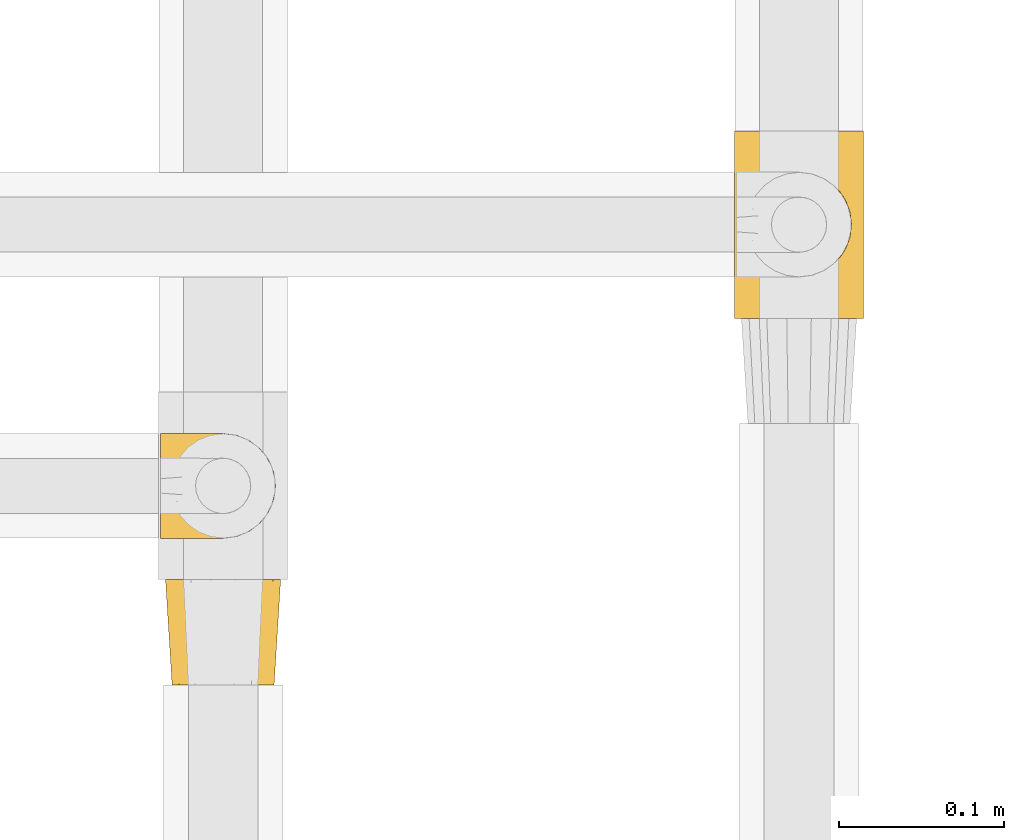
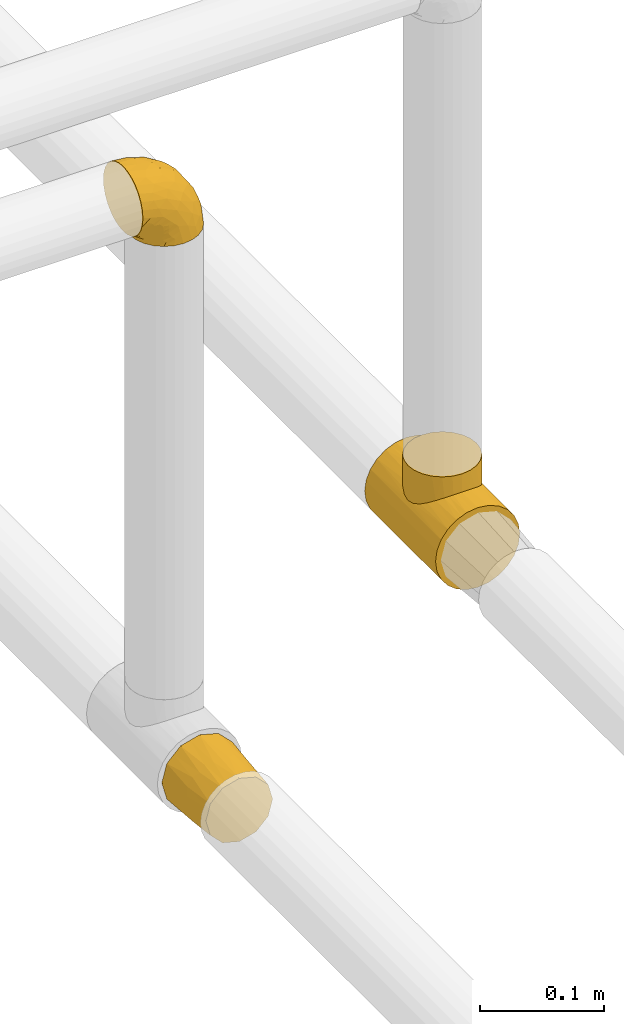
# One storey, part 14 of 39: 3 coverings.
"""IFC2X3 building model written with IfcOpenShell, lengths in millimetres."""

from ifc_helpers import new_model, entity, si_unit, converted_unit, derived_unit, direction, frame, origin, place, context, subcontext, project, spatial, faceted_brep, element, save


model = new_model("IFC2X3")

# Units and contexts
model_context = context("Model", 3, precision=0.01, world=origin(), true_north=direction((6.12303176911189e-17, 1.0)))
body_context = subcontext(model_context, "Body", "Model", "MODEL_VIEW")
ifc_project = project(units=[si_unit("LENGTHUNIT", "METRE", prefix="MILLI"), si_unit("AREAUNIT", "SQUARE_METRE"), si_unit("VOLUMEUNIT", "CUBIC_METRE"), converted_unit("PLANEANGLEUNIT", "DEGREE", entity("IfcRatioMeasure", 0.0174532925199433), si_unit("PLANEANGLEUNIT", "RADIAN"), dimensions=[0, 0, 0, 0, 0, 0, 0]), si_unit("MASSUNIT", "GRAM", prefix="KILO"), derived_unit("MASSDENSITYUNIT", [(si_unit("MASSUNIT", "GRAM", prefix="KILO"), 1), (si_unit("LENGTHUNIT", "METRE"), -3)]), derived_unit("MOMENTOFINERTIAUNIT", [(si_unit("LENGTHUNIT", "METRE"), 4)]), si_unit("TIMEUNIT", "SECOND"), si_unit("FREQUENCYUNIT", "HERTZ"), si_unit("THERMODYNAMICTEMPERATUREUNIT", "DEGREE_CELSIUS"), derived_unit("THERMALTRANSMITTANCEUNIT", [(si_unit("MASSUNIT", "GRAM", prefix="KILO"), 1), (si_unit("THERMODYNAMICTEMPERATUREUNIT", "KELVIN"), -1), (si_unit("TIMEUNIT", "SECOND"), -3)]), derived_unit("VOLUMETRICFLOWRATEUNIT", [(si_unit("LENGTHUNIT", "METRE"), 3), (si_unit("TIMEUNIT", "SECOND"), -1)]), derived_unit("MASSFLOWRATEUNIT", [(si_unit("MASSUNIT", "GRAM", prefix="KILO"), 1), (si_unit("TIMEUNIT", "SECOND"), -1)]), derived_unit("ROTATIONALFREQUENCYUNIT", [(si_unit("TIMEUNIT", "SECOND"), -1)]), si_unit("ELECTRICCURRENTUNIT", "AMPERE"), si_unit("ELECTRICVOLTAGEUNIT", "VOLT"), si_unit("POWERUNIT", "WATT"), si_unit("FORCEUNIT", "NEWTON", prefix="KILO"), si_unit("ILLUMINANCEUNIT", "LUX"), si_unit("LUMINOUSFLUXUNIT", "LUMEN"), si_unit("LUMINOUSINTENSITYUNIT", "CANDELA"), derived_unit("USERDEFINED", [(si_unit("MASSUNIT", "GRAM", prefix="KILO"), -1), (si_unit("LENGTHUNIT", "METRE"), -2), (si_unit("TIMEUNIT", "SECOND"), 3), (si_unit("LUMINOUSFLUXUNIT", "LUMEN"), 1)]), derived_unit("LINEARVELOCITYUNIT", [(si_unit("LENGTHUNIT", "METRE"), 1), (si_unit("TIMEUNIT", "SECOND"), -1)]), si_unit("PRESSUREUNIT", "PASCAL"), derived_unit("USERDEFINED", [(si_unit("LENGTHUNIT", "METRE"), -2), (si_unit("MASSUNIT", "GRAM", prefix="KILO"), 1), (si_unit("TIMEUNIT", "SECOND"), -2)]), derived_unit("LINEARFORCEUNIT", [(si_unit("MASSUNIT", "GRAM", prefix="KILO"), 1), (si_unit("LENGTHUNIT", "METRE"), 1), (si_unit("TIMEUNIT", "SECOND"), -2), (si_unit("LENGTHUNIT", "METRE"), -1)]), derived_unit("PLANARFORCEUNIT", [(si_unit("MASSUNIT", "GRAM", prefix="KILO"), 1), (si_unit("LENGTHUNIT", "METRE"), 1), (si_unit("TIMEUNIT", "SECOND"), -2), (si_unit("LENGTHUNIT", "METRE"), -2)])], contexts=[model_context])

# Site, building, storey
site_placement = place(None, origin())
site = spatial("IfcSite", under=ifc_project, at=site_placement, CompositionType="ELEMENT")
building_placement = place(site_placement, origin())
building = spatial("IfcBuilding", under=site, at=building_placement, CompositionType="ELEMENT")
storey_placement = place(building_placement, frame((0.0, 0.0, 24000.0)))
storey = spatial("IfcBuildingStorey", under=building, at=storey_placement, Name="07", CompositionType="ELEMENT", Elevation=24000.0)

# Coverings
covering_1_placement = place(storey_placement, frame((31040.4, 8217.73, 3160.4)))
element("IfcCovering", 1, at=covering_1_placement, inside=storey, Name=":ADSK_", ObjectType=":ADSK_", PredefinedType="INSULATION", context=body_context, shape_type="Brep", body=[
    faceted_brep([(1.6, 26.36, 70.65), (1.6, 33.45, 71.45), (1.6, 40.54, 70.65), (1.6, 47.27, 68.29), (1.6, 53.31, 64.49), (1.6, 58.35, 59.45), (1.6, 62.14, 53.41), (1.6, 64.5, 46.68), (1.6, 65.3, 39.6), (1.6, 64.86, 35.69), (1.6, 64.5, 32.5), (1.6, 63.32, 29.14), (1.6, 62.14, 25.77), (1.6, 58.34, 19.73), (1.6, 53.3, 14.69), (1.6, 47.26, 10.9), (1.6, 40.53, 8.54), (1.6, 33.45, 7.75), (1.6, 26.35, 8.54), (1.6, 19.62, 10.9), (1.6, 13.58, 14.7), (1.6, 8.54, 19.74), (1.6, 4.75, 25.78), (1.6, 3.57, 29.15), (1.6, 2.39, 32.51), (1.6, 2.03, 35.69), (1.6, 1.81, 37.64), (1.6, 1.6, 39.6), (1.6, 2.39, 46.69), (1.6, 4.75, 53.42), (1.6, 8.55, 59.46), (1.6, 13.59, 64.5), (1.6, 19.63, 68.29), (23.67, 61.03, 1.6), (27.51, 62.62, 1.6), (31.35, 64.21, 1.6), (35.67, 64.78, 1.6), (37.63, 65.04, 1.6), (39.6, 65.3, 1.6), (47.84, 64.21, 1.6), (55.52, 61.03, 1.6), (62.12, 55.97, 1.6), (67.18, 49.37, 1.6), (70.36, 41.69, 1.6), (71.45, 33.45, 1.6), (70.36, 25.2, 1.6), (67.18, 17.52, 1.6), (62.12, 10.92, 1.6), (55.52, 5.86, 1.6), (47.84, 2.68, 1.6), (39.6, 1.6, 1.6), (35.67, 2.11, 1.6), (31.35, 2.68, 1.6), (27.51, 4.27, 1.6), (23.67, 5.86, 1.6), (20.37, 8.39, 1.6), (17.07, 10.92, 1.6), (12.01, 17.52, 1.6), (8.83, 25.2, 1.6), (7.75, 33.45, 1.6), (8.83, 41.69, 1.6), (12.01, 49.37, 1.6), (17.07, 55.97, 1.6), (20.37, 58.5, 1.6), (33.94, 2.87, 35.56), (20.6, 1.6, 34.5), (24.07, 1.6, 31.03), (27.55, 1.6, 27.55), (31.03, 1.6, 24.07), (34.5, 1.6, 20.6), (68.79, 33.45, 14.96), (53.62, 10.76, 32.2), (50.17, 5.89, 25.13), (58.62, 9.64, 17.37), (67.51, 22.45, 17.86), (61.03, 16.56, 27.91), (64.5, 15.17, 13.85), (17.98, 12.49, 61.37), (61.71, 25.02, 34.87), (52.25, 18.64, 44.22), (16.72, 2.29, 43.56), (39.09, 6.11, 40.93), (25.86, 5.18, 48.36), (44.07, 2.43, 17.22), (44.36, 11.11, 44.67), (31.35, 26.19, 63.86), (17.72, 24.02, 68.09), (29.45, 19.02, 61.87), (52.37, 4.77, 12.15), (35.28, 1.6, 17.69), (36.06, 1.6, 14.79), (36.84, 1.6, 11.89), (37.61, 1.6, 8.99), (38.11, 1.6, 7.14), (38.61, 1.6, 5.29), (14.07, 7.57, 56.77), (13.65, 17.54, 66.08), (14.96, 33.45, 68.79), (13.32, 4.36, 51.2), (3.44, 1.6, 39.1), (5.29, 1.6, 38.61), (8.99, 1.6, 37.61), (11.89, 1.6, 36.84), (14.79, 1.6, 36.06), (17.69, 1.6, 35.28), (29.19, 9.86, 54.2), (28.91, 14.05, 58.65), (68.17, 28.37, 21.36), (28.33, 33.45, 66.13), (53.45, 25.8, 46.99), (58.56, 33.45, 39.66), (50.99, 33.45, 50.99), (43.14, 22.54, 55.34), (39.23, 15.6, 53.83), (66.13, 33.45, 28.33), (45.6, 28.45, 55.34), (39.66, 33.45, 58.56), (18.04, 9.47, 6.06), (22.76, 5.83, 8.03), (21.95, 5.65, 11.06), (32.18, 2.31, 8.19), (29.08, 2.89, 10.89), (20.77, 2.68, 24.37), (4.75, 22.04, 9.23), (11.03, 5.47, 22.33), (6.78, 5.05, 24.59), (5.68, 7.86, 20.19), (7.71, 25.25, 5.45), (4.42, 28.09, 7.56), (5.94, 33.45, 5.94), (14.52, 12.77, 6.36), (11.63, 2.62, 29.84), (6.6, 3.56, 28.12), (7.33, 11.92, 14.94), (12.48, 11.98, 11.12), (7.99, 17.45, 9.87), (11.14, 17.1, 6.36), (14.07, 7.66, 16.34), (15.37, 4.47, 22.18), (10.81, 7.62, 18.62), (7.89, 2.29, 32.34), (26.18, 3.16, 15.29), (5.8, 16.64, 11.7), (9.94, 12.23, 13.14), (22.23, 4.54, 15.04), (18.39, 7.84, 10.61), (17.71, 2.55, 27.21), (16.87, 7.37, 14.05), (13.24, 3.18, 27.14), (24.95, 4.97, 5.74), (26.59, 2.38, 19.92), (26.16, 1.99, 23.61), (22.11, 3.56, 19.14), (17.43, 4.66, 20.12), (4.75, 44.85, 9.23), (5.8, 50.24, 11.69), (7.99, 49.43, 9.87), (14.07, 59.23, 16.33), (10.06, 54.76, 13.17), (11.54, 59.54, 18.65), (7.71, 41.64, 5.45), (7.89, 64.6, 32.33), (8.99, 65.3, 37.61), (11.89, 65.3, 36.84), (14.79, 65.3, 36.06), (4.42, 38.79, 7.56), (22.42, 62.38, 14.85), (27.95, 64.44, 17.26), (22.22, 61.27, 10.58), (39.1, 65.3, 3.44), (36.84, 65.3, 11.89), (37.61, 65.3, 8.99), (38.61, 65.3, 5.29), (21.49, 59.93, 5.65), (26.52, 62.73, 6.88), (18.09, 60.51, 14.93), (18.39, 59.05, 10.6), (13.88, 56.02, 11.09), (11.14, 49.79, 6.36), (32.18, 64.58, 8.19), (34.5, 65.3, 20.6), (31.03, 65.3, 24.07), (11.65, 64.27, 29.86), (5.67, 59.01, 20.16), (6.81, 61.84, 24.58), (5.29, 65.3, 38.61), (7.14, 65.3, 38.11), (7.34, 54.97, 14.93), (36.06, 65.3, 14.79), (31.38, 64.66, 12.32), (19.83, 63.94, 23.91), (27.55, 65.3, 27.55), (22.94, 63.6, 19.33), (6.6, 63.33, 28.11), (17.93, 57.32, 6.0), (14.52, 54.15, 6.44), (17.45, 64.5, 28.13), (11.03, 61.42, 22.32), (17.69, 65.3, 35.28), (20.6, 65.3, 34.5), (12.33, 63.43, 26.65), (30.27, 64.69, 15.34), (35.28, 65.3, 17.69), (25.9, 62.87, 10.31), (24.07, 65.3, 31.03), (58.62, 57.25, 17.37), (13.32, 62.54, 51.19), (16.72, 64.6, 43.56), (44.07, 64.46, 17.22), (61.71, 41.87, 34.87), (67.51, 44.44, 17.86), (61.03, 50.33, 27.92), (50.18, 61.0, 25.12), (33.92, 64.03, 35.57), (39.08, 60.79, 40.93), (53.62, 56.13, 32.19), (68.17, 38.52, 21.36), (52.37, 62.12, 12.15), (64.5, 51.72, 13.85), (25.86, 61.71, 48.35), (14.07, 59.33, 56.76), (29.18, 57.04, 54.19), (29.46, 47.88, 61.86), (17.73, 42.88, 68.09), (31.37, 40.71, 63.85), (17.99, 54.41, 61.36), (53.45, 41.09, 47.0), (39.25, 51.29, 53.81), (28.92, 52.85, 58.64), (13.65, 49.36, 66.07), (52.23, 48.25, 44.24), (43.13, 44.35, 55.34), (44.36, 55.79, 44.67), (45.6, 38.44, 55.34)], [[[0, 1, 2, 3, 4, 5, 6, 7, 8, 9, 10, 11, 12, 13, 14, 15, 16, 17, 18, 19, 20, 21, 22, 23, 24, 25, 26, 27, 28, 29, 30, 31, 32]], [[33, 34, 35, 36, 37, 38, 39, 40, 41, 42, 43, 44, 45, 46, 47, 48, 49, 50, 51, 52, 53, 54, 55, 56, 57, 58, 59, 60, 61, 62, 63]], [[64, 65, 66, 67, 68, 69]], [[45, 44, 70]], [[71, 72, 73]], [[74, 75, 76]], [[77, 31, 30]], [[75, 78, 79]], [[27, 80, 28]], [[74, 46, 45]], [[64, 81, 82]], [[46, 76, 47]], [[83, 50, 49]], [[48, 47, 73]], [[71, 79, 84]], [[85, 86, 87]], [[49, 48, 88]], [[83, 69, 89, 90, 91, 92, 93, 94, 50]], [[95, 77, 30]], [[75, 74, 78]], [[87, 86, 96]], [[96, 86, 32]], [[96, 32, 31]], [[0, 86, 97]], [[83, 64, 69]], [[98, 80, 82]], [[73, 72, 88]], [[64, 80, 65]], [[1, 0, 97]], [[80, 27, 99, 100, 101, 102, 103, 104, 65]], [[77, 105, 106]], [[64, 82, 80]], [[70, 107, 45]], [[77, 95, 105]], [[82, 95, 98]], [[95, 30, 29]], [[74, 107, 78]], [[86, 0, 32]], [[72, 71, 81]], [[85, 108, 86]], [[76, 73, 47]], [[71, 84, 81]], [[109, 110, 111]], [[87, 112, 85]], [[79, 109, 112]], [[79, 112, 113]], [[88, 83, 49]], [[64, 83, 72]], [[31, 77, 96]], [[87, 96, 77]], [[98, 95, 29]], [[105, 95, 82]], [[81, 105, 82]], [[105, 84, 113]], [[29, 28, 98]], [[114, 107, 70]], [[80, 98, 28]], [[73, 75, 71]], [[79, 71, 75]], [[74, 76, 46]], [[73, 76, 75]], [[78, 107, 114]], [[45, 107, 74]], [[87, 113, 112]], [[115, 85, 112]], [[109, 79, 78]], [[113, 87, 106]], [[116, 115, 111]], [[116, 108, 85]], [[79, 113, 84]], [[109, 78, 110]], [[115, 109, 111]], [[85, 115, 116]], [[109, 115, 112]], [[72, 81, 64]], [[105, 81, 84]], [[73, 88, 48]], [[83, 88, 72]], [[86, 108, 97]], [[78, 114, 110]], [[113, 106, 105]], [[87, 77, 106]], [[117, 118, 119]], [[52, 120, 54, 53]], [[91, 120, 52]], [[91, 90, 120]], [[90, 121, 120]], [[122, 67, 66]], [[18, 123, 19]], [[124, 125, 126]], [[127, 59, 58]], [[128, 129, 127]], [[130, 57, 117]], [[131, 132, 125]], [[19, 133, 20]], [[128, 18, 17]], [[134, 135, 136]], [[137, 138, 139]], [[131, 103, 140]], [[22, 140, 23]], [[131, 65, 104, 103]], [[99, 27, 26, 25, 24, 101, 100]], [[141, 118, 121]], [[19, 123, 142]], [[52, 51, 50, 94, 93, 92, 91]], [[129, 128, 17]], [[117, 56, 118]], [[135, 134, 143]], [[139, 126, 133]], [[119, 144, 145]], [[127, 135, 123]], [[136, 58, 57]], [[101, 24, 23]], [[124, 138, 146]], [[140, 101, 23]], [[145, 147, 134]], [[140, 132, 131]], [[140, 103, 102, 101]], [[140, 22, 132]], [[146, 148, 124]], [[121, 69, 141]], [[55, 149, 118]], [[150, 151, 152]], [[147, 137, 134]], [[144, 150, 152]], [[152, 151, 122]], [[138, 122, 146]], [[59, 127, 129]], [[123, 18, 128]], [[58, 136, 127]], [[135, 127, 136]], [[121, 90, 89, 69]], [[120, 121, 149]], [[122, 66, 146]], [[153, 122, 138]], [[141, 69, 68]], [[127, 123, 128]], [[123, 135, 142]], [[143, 142, 135]], [[19, 142, 133]], [[66, 65, 146]], [[148, 65, 131]], [[22, 21, 132]], [[125, 132, 21]], [[126, 125, 21]], [[148, 125, 124]], [[21, 20, 126]], [[133, 126, 20]], [[139, 138, 124]], [[153, 138, 137]], [[126, 139, 124]], [[139, 133, 143]], [[147, 153, 137]], [[152, 122, 153]], [[134, 136, 130]], [[137, 139, 143]], [[144, 147, 145]], [[153, 147, 152]], [[65, 148, 146]], [[125, 148, 131]], [[141, 144, 119]], [[55, 54, 149]], [[137, 143, 134]], [[142, 143, 133]], [[130, 117, 145]], [[57, 56, 117]], [[134, 130, 145]], [[57, 130, 136]], [[150, 144, 141]], [[147, 144, 152]], [[141, 68, 150]], [[151, 68, 67]], [[117, 119, 145]], [[141, 119, 118]], [[68, 151, 150]], [[122, 151, 67]], [[118, 56, 55]], [[120, 149, 54]], [[118, 149, 121]], [[154, 155, 156]], [[157, 158, 159]], [[129, 160, 59]], [[161, 162, 163, 164]], [[165, 160, 129]], [[166, 167, 168]], [[169, 38, 37, 36, 35, 170, 171, 172]], [[63, 173, 174]], [[175, 176, 177]], [[60, 178, 61]], [[179, 35, 34, 33]], [[160, 60, 59]], [[180, 167, 181]], [[129, 17, 165]], [[182, 161, 164]], [[183, 13, 184]], [[9, 8, 185, 186, 162, 10]], [[187, 155, 15]], [[188, 179, 189]], [[187, 15, 14]], [[190, 191, 192]], [[182, 193, 161]], [[194, 176, 168]], [[176, 195, 177]], [[196, 190, 197]], [[11, 10, 162]], [[11, 161, 12]], [[187, 14, 183]], [[12, 161, 193]], [[156, 158, 177]], [[165, 17, 16]], [[194, 195, 176]], [[187, 159, 158]], [[179, 174, 189]], [[182, 164, 198, 199]], [[200, 199, 196]], [[193, 184, 13]], [[194, 168, 173]], [[201, 202, 189]], [[16, 154, 165]], [[160, 156, 178]], [[160, 165, 154]], [[178, 60, 160]], [[170, 35, 179]], [[188, 170, 179]], [[189, 174, 203]], [[174, 179, 33]], [[201, 189, 203]], [[181, 192, 191]], [[167, 180, 201]], [[192, 175, 190]], [[159, 190, 157]], [[15, 154, 16]], [[204, 196, 199]], [[204, 191, 190]], [[160, 154, 156]], [[15, 155, 154]], [[158, 155, 187]], [[203, 173, 168]], [[192, 181, 167]], [[190, 196, 204]], [[200, 196, 197]], [[184, 193, 182]], [[13, 12, 193]], [[200, 184, 182]], [[184, 200, 183]], [[187, 183, 197]], [[14, 13, 183]], [[162, 161, 11]], [[63, 62, 173]], [[174, 33, 63]], [[173, 62, 194]], [[174, 173, 203]], [[62, 61, 194]], [[195, 61, 178]], [[61, 195, 194]], [[177, 195, 178]], [[156, 177, 178]], [[175, 192, 166]], [[166, 168, 176]], [[167, 203, 168]], [[175, 166, 176]], [[167, 166, 192]], [[177, 157, 175]], [[190, 175, 157]], [[187, 197, 159]], [[190, 159, 197]], [[177, 158, 157]], [[155, 158, 156]], [[167, 201, 203]], [[200, 197, 183]], [[202, 201, 180]], [[202, 188, 189]], [[199, 200, 182]], [[41, 40, 205]], [[206, 207, 7]], [[208, 38, 169, 172, 171, 170, 188, 202, 180]], [[209, 210, 211]], [[212, 213, 214]], [[212, 215, 205]], [[43, 210, 216]], [[217, 40, 39]], [[216, 114, 70]], [[208, 213, 212]], [[205, 40, 217]], [[218, 42, 41]], [[216, 209, 114]], [[42, 218, 210]], [[214, 213, 219]], [[219, 220, 221]], [[199, 207, 213]], [[213, 207, 219]], [[8, 7, 207]], [[222, 223, 224]], [[4, 225, 5]], [[2, 97, 223]], [[110, 226, 111]], [[225, 220, 5]], [[227, 221, 228]], [[223, 229, 3]], [[2, 223, 3]], [[230, 231, 226]], [[224, 223, 108]], [[42, 210, 43]], [[230, 209, 211]], [[222, 225, 229]], [[38, 208, 39]], [[3, 229, 4]], [[213, 180, 181, 191, 204, 199]], [[220, 206, 6]], [[5, 220, 6]], [[207, 199, 198, 164, 163, 162, 186, 185, 8]], [[212, 214, 215]], [[218, 205, 211]], [[211, 215, 230]], [[226, 110, 209]], [[222, 231, 227]], [[222, 224, 231]], [[213, 208, 180]], [[217, 208, 212]], [[222, 229, 223]], [[225, 4, 229]], [[221, 220, 225]], [[206, 220, 219]], [[228, 221, 225]], [[214, 221, 232]], [[207, 206, 219]], [[44, 43, 70]], [[7, 6, 206]], [[230, 215, 232]], [[211, 205, 215]], [[205, 218, 41]], [[210, 218, 211]], [[43, 216, 70]], [[209, 216, 210]], [[233, 116, 111]], [[230, 232, 227]], [[224, 116, 233]], [[230, 226, 209]], [[224, 108, 116]], [[230, 227, 231]], [[221, 227, 232]], [[233, 226, 231]], [[225, 222, 228]], [[226, 233, 111]], [[224, 233, 231]], [[221, 214, 219]], [[214, 232, 215]], [[208, 217, 39]], [[205, 217, 212]], [[97, 2, 1]], [[97, 108, 223]], [[110, 114, 209]], [[227, 228, 222]]]),
])
covering_2_placement = place(storey_placement, frame((31043.4, 8130.17, 2623.4)))
element("IfcCovering", 2, at=covering_2_placement, inside=storey, Name=":ADSK_", ObjectType=":ADSK_", PredefinedType="INSULATION", context=body_context, shape_type="Brep", body=[
    faceted_brep([(8.36, 0.0, 46.92), (5.59, 0.0, 36.6), (8.36, 0.0, 26.27), (9.75, 0.0, 21.1), (15.42, 0.0, 15.42), (21.09, 0.0, 9.75), (26.27, 0.0, 8.36), (36.59, 0.0, 5.6), (46.92, 0.0, 8.36), (52.09, 0.0, 9.75), (57.77, 0.0, 15.42), (63.44, 0.0, 21.1), (64.83, 0.0, 26.27), (67.59, 0.0, 36.6), (64.83, 0.0, 46.92), (63.44, 0.0, 52.1), (57.77, 0.0, 57.77), (52.09, 0.0, 63.44), (46.92, 0.0, 64.83), (36.59, 0.0, 67.6), (26.27, 0.0, 64.83), (21.09, 0.0, 63.44), (15.42, 0.0, 57.77), (9.75, 0.0, 52.1), (45.35, 64.0, 69.25), (54.1, 64.0, 66.91), (60.5, 64.0, 60.5), (66.91, 64.0, 54.1), (69.25, 64.0, 45.35), (71.6, 64.0, 36.6), (69.25, 64.0, 27.85), (66.91, 64.0, 19.1), (60.5, 64.0, 12.69), (54.1, 64.0, 6.28), (45.35, 64.0, 3.94), (36.6, 64.0, 1.6), (27.85, 64.0, 3.94), (19.1, 64.0, 6.28), (12.69, 64.0, 12.69), (6.28, 64.0, 19.1), (3.94, 64.0, 27.85), (1.6, 64.0, 36.6), (3.94, 64.0, 45.35), (6.28, 64.0, 54.1), (12.69, 64.0, 60.5), (19.1, 64.0, 66.91), (27.85, 64.0, 69.25), (36.6, 64.0, 71.6), (6.68, 32.0, 22.65), (10.56, 28.99, 16.62), (4.58, 28.84, 29.44), (15.12, 32.0, 11.54), (22.65, 32.0, 6.68), (29.44, 28.84, 4.58), (36.59, 32.0, 3.6), (3.59, 32.0, 36.6), (50.54, 32.0, 6.68), (56.57, 28.99, 10.56), (43.75, 28.84, 4.58), (61.65, 32.0, 15.12), (66.51, 32.0, 22.65), (68.61, 28.84, 29.44), (69.59, 32.0, 36.6), (66.51, 32.0, 50.54), (62.63, 28.99, 56.57), (68.61, 28.84, 43.75), (58.07, 32.0, 61.65), (50.54, 32.0, 66.51), (43.75, 28.84, 68.61), (36.59, 32.0, 69.6), (22.65, 32.0, 66.51), (16.62, 28.99, 62.63), (29.44, 28.84, 68.61), (11.54, 32.0, 58.07), (6.68, 32.0, 50.54), (4.58, 28.84, 43.75)], [[[0, 1, 2, 3, 4, 5, 6, 7, 8, 9, 10, 11, 12, 13, 14, 15, 16, 17, 18, 19, 20, 21, 22, 23]], [[24, 25, 26, 27, 28, 29, 30, 31, 32, 33, 34, 35, 36, 37, 38, 39, 40, 41, 42, 43, 44, 45, 46, 47]], [[48, 40, 39]], [[39, 49, 48]], [[41, 40, 50]], [[40, 48, 50]], [[38, 49, 39]], [[51, 49, 38]], [[6, 52, 53]], [[5, 4, 51]], [[48, 2, 50]], [[53, 35, 54, 7]], [[4, 49, 51]], [[49, 3, 48]], [[49, 4, 3]], [[48, 3, 2]], [[2, 1, 50]], [[50, 1, 55, 41]], [[38, 37, 51]], [[51, 37, 52]], [[5, 52, 6]], [[52, 5, 51]], [[37, 36, 52]], [[53, 52, 36]], [[7, 6, 53]], [[35, 53, 36]], [[56, 34, 33]], [[33, 57, 56]], [[35, 34, 58]], [[34, 56, 58]], [[32, 57, 33]], [[59, 57, 32]], [[12, 60, 61]], [[11, 10, 59]], [[56, 8, 58]], [[61, 29, 62, 13]], [[10, 57, 59]], [[57, 9, 56]], [[57, 10, 9]], [[56, 9, 8]], [[8, 7, 58]], [[58, 7, 54, 35]], [[32, 31, 59]], [[59, 31, 60]], [[11, 60, 12]], [[60, 11, 59]], [[31, 30, 60]], [[61, 60, 30]], [[13, 12, 61]], [[29, 61, 30]], [[63, 28, 27]], [[27, 64, 63]], [[29, 28, 65]], [[28, 63, 65]], [[26, 64, 27]], [[66, 64, 26]], [[18, 67, 68]], [[17, 16, 66]], [[63, 14, 65]], [[68, 47, 69, 19]], [[16, 64, 66]], [[64, 15, 63]], [[64, 16, 15]], [[63, 15, 14]], [[14, 13, 65]], [[65, 13, 62, 29]], [[26, 25, 66]], [[66, 25, 67]], [[17, 67, 18]], [[67, 17, 66]], [[25, 24, 67]], [[68, 67, 24]], [[19, 18, 68]], [[47, 68, 24]], [[70, 46, 45]], [[45, 71, 70]], [[47, 46, 72]], [[46, 70, 72]], [[44, 71, 45]], [[73, 71, 44]], [[0, 74, 75]], [[23, 22, 73]], [[70, 20, 72]], [[75, 41, 55, 1]], [[22, 71, 73]], [[71, 21, 70]], [[71, 22, 21]], [[70, 21, 20]], [[20, 19, 72]], [[72, 19, 69, 47]], [[44, 43, 73]], [[73, 43, 74]], [[23, 74, 0]], [[74, 23, 73]], [[43, 42, 74]], [[75, 74, 42]], [[1, 0, 75]], [[41, 75, 42]]]),
])
covering_3_placement = place(storey_placement, frame((31389.25, 8352.96, 2619.25)))
element("IfcCovering", 3, at=covering_3_placement, inside=storey, Name=":ADSK_", ObjectType=":ADSK_", PredefinedType="INSULATION", context=body_context, shape_type="Brep", body=[
    faceted_brep([(60.32, 114.0, 6.84), (50.88, 114.0, 2.93), (40.75, 114.0, 1.6), (30.61, 114.0, 2.93), (21.17, 114.0, 6.84), (13.06, 114.0, 13.06), (6.84, 114.0, 21.17), (2.93, 114.0, 30.61), (1.6, 114.0, 40.75), (2.93, 114.0, 50.88), (6.84, 114.0, 60.32), (13.06, 114.0, 68.43), (17.12, 114.0, 71.54), (21.17, 114.0, 74.65), (25.89, 114.0, 76.61), (30.61, 114.0, 78.56), (35.68, 114.0, 79.23), (40.75, 114.0, 79.9), (45.81, 114.0, 79.23), (50.88, 114.0, 78.56), (55.6, 114.0, 76.61), (60.32, 114.0, 74.65), (64.37, 114.0, 71.54), (68.43, 114.0, 68.43), (74.65, 114.0, 60.32), (78.56, 114.0, 50.88), (79.9, 114.0, 40.75), (78.56, 114.0, 30.61), (74.65, 114.0, 21.17), (68.43, 114.0, 13.06), (2.93, 0.0, 50.88), (1.6, 0.0, 40.75), (2.93, 0.0, 30.61), (6.84, 0.0, 21.17), (13.06, 0.0, 13.06), (21.17, 0.0, 6.84), (30.61, 0.0, 2.93), (40.75, 0.0, 1.6), (50.88, 0.0, 2.93), (60.32, 0.0, 6.84), (68.43, 0.0, 13.06), (74.65, 0.0, 21.17), (78.56, 0.0, 30.61), (79.9, 0.0, 40.75), (78.56, 0.0, 50.88), (74.65, 0.0, 60.32), (68.43, 0.0, 68.43), (64.37, 0.0, 71.54), (60.32, 0.0, 74.65), (55.6, 0.0, 76.61), (50.88, 0.0, 78.56), (45.81, 0.0, 79.23), (40.75, 0.0, 79.9), (35.68, 0.0, 79.23), (30.61, 0.0, 78.56), (25.89, 0.0, 76.61), (21.17, 0.0, 74.65), (17.12, 0.0, 71.54), (13.06, 0.0, 68.43), (6.84, 0.0, 60.32), (15.77, 37.23, 70.9), (12.16, 42.96, 67.49), (20.53, 32.39, 74.27), (29.82, 86.7, 78.17), (26.39, 85.43, 77.17), (9.77, 49.58, 64.69), (8.9, 57.0, 63.51), (9.77, 64.42, 64.69), (37.0, 88.4, 79.53), (40.75, 88.85, 79.9), (40.75, 25.15, 79.9), (37.0, 25.6, 79.53), (12.16, 71.04, 67.49), (15.77, 76.77, 70.9), (20.53, 81.61, 74.27), (26.39, 28.57, 77.17), (33.25, 26.04, 79.17), (29.82, 27.3, 78.17), (33.25, 87.96, 79.17), (44.49, 25.6, 79.53), (48.24, 26.04, 79.17), (55.1, 28.57, 77.17), (60.96, 32.39, 74.27), (51.67, 27.3, 78.17), (48.24, 87.96, 79.17), (44.49, 88.4, 79.53), (55.1, 85.43, 77.17), (60.96, 81.61, 74.27), (51.67, 86.7, 78.17), (65.72, 76.77, 70.9), (65.72, 37.23, 70.9), (69.33, 42.96, 67.49), (71.72, 49.58, 64.69), (72.6, 57.0, 63.51), (69.33, 71.04, 67.49), (71.72, 64.42, 64.69), (8.9, 57.0, 97.75), (9.98, 48.76, 97.75), (13.16, 41.07, 97.75), (18.22, 34.48, 97.75), (24.82, 29.42, 97.75), (32.5, 26.24, 97.75), (40.75, 25.15, 97.75), (48.99, 26.24, 97.75), (56.67, 29.42, 97.75), (63.27, 34.48, 97.75), (68.33, 41.07, 97.75), (71.51, 48.76, 97.75), (72.6, 57.0, 97.75), (71.51, 65.24, 97.75), (68.33, 72.92, 97.75), (63.27, 79.52, 97.75), (56.67, 84.58, 97.75), (48.99, 87.76, 97.75), (40.75, 88.85, 97.75), (32.5, 87.76, 97.75), (24.82, 84.58, 97.75), (18.22, 79.52, 97.75), (13.16, 72.92, 97.75), (9.98, 65.24, 97.75)], [[[0, 1, 2, 3, 4, 5, 6, 7, 8, 9, 10, 11, 12, 13, 14, 15, 16, 17, 18, 19, 20, 21, 22, 23, 24, 25, 26, 27, 28, 29]], [[30, 31, 32, 33, 34, 35, 36, 37, 38, 39, 40, 41, 42, 43, 44, 45, 46, 47, 48, 49, 50, 51, 52, 53, 54, 55, 56, 57, 58, 59]], [[35, 34, 5, 4]], [[3, 2, 37, 36]], [[36, 35, 4, 3]], [[6, 33, 32, 7]], [[7, 32, 31, 8]], [[5, 34, 33, 6]], [[30, 9, 8, 31]], [[59, 10, 9, 30]], [[58, 60, 61]], [[57, 56, 62]], [[63, 14, 64]], [[61, 65, 58]], [[60, 58, 57]], [[58, 65, 59]], [[65, 66, 59]], [[67, 11, 10]], [[17, 68, 69]], [[70, 71, 52]], [[72, 11, 67]], [[73, 11, 72]], [[74, 12, 73]], [[67, 10, 66]], [[66, 10, 59]], [[75, 56, 55]], [[62, 56, 75]], [[76, 54, 53]], [[55, 54, 77]], [[14, 63, 15]], [[52, 71, 53]], [[76, 53, 71]], [[77, 75, 55]], [[74, 13, 12]], [[54, 76, 77]], [[13, 64, 14]], [[64, 13, 74]], [[16, 78, 68]], [[73, 12, 11]], [[17, 16, 68]], [[16, 15, 78]], [[78, 15, 63]], [[60, 57, 62]], [[51, 79, 52]], [[80, 51, 50]], [[49, 48, 81]], [[82, 81, 48]], [[47, 82, 48]], [[50, 83, 80]], [[51, 80, 79]], [[84, 18, 85]], [[85, 17, 69]], [[52, 79, 70]], [[86, 87, 21]], [[17, 85, 18]], [[19, 88, 20]], [[89, 22, 87]], [[20, 88, 86]], [[82, 47, 90]], [[83, 49, 81]], [[90, 46, 91]], [[46, 90, 47]], [[91, 46, 92]], [[49, 83, 50]], [[24, 45, 44, 25]], [[93, 92, 45]], [[45, 92, 46]], [[44, 43, 26, 25]], [[84, 19, 18]], [[94, 95, 23]], [[86, 21, 20]], [[22, 21, 87]], [[23, 89, 94]], [[95, 24, 23]], [[19, 84, 88]], [[93, 24, 95]], [[93, 45, 24]], [[89, 23, 22]], [[27, 42, 41, 28]], [[28, 41, 40, 29]], [[43, 42, 27, 26]], [[0, 39, 38, 1]], [[1, 38, 37, 2]], [[29, 40, 39, 0]], [[96, 97, 98, 99, 100, 101, 102, 103, 104, 105, 106, 107, 108, 109, 110, 111, 112, 113, 114, 115, 116, 117, 118, 119]], [[76, 102, 101]], [[75, 101, 100]], [[102, 76, 71, 70]], [[62, 75, 100]], [[101, 75, 77, 76]], [[100, 99, 62]], [[60, 99, 98]], [[61, 98, 97]], [[65, 97, 96]], [[60, 98, 61]], [[65, 61, 97]], [[66, 65, 96]], [[99, 60, 62]], [[67, 96, 119]], [[72, 119, 118]], [[66, 96, 67]], [[67, 119, 72]], [[118, 73, 72]], [[118, 117, 73]], [[74, 117, 116]], [[64, 116, 115]], [[78, 115, 114]], [[64, 74, 116]], [[114, 69, 68, 78]], [[115, 78, 63, 64]], [[117, 74, 73]], [[84, 114, 113]], [[86, 113, 112]], [[114, 84, 85, 69]], [[87, 86, 112]], [[113, 86, 88, 84]], [[112, 111, 87]], [[89, 111, 110]], [[94, 110, 109]], [[95, 109, 108]], [[89, 110, 94]], [[95, 94, 109]], [[93, 95, 108]], [[111, 89, 87]], [[92, 108, 107]], [[91, 107, 106]], [[93, 108, 92]], [[92, 107, 91]], [[106, 90, 91]], [[106, 105, 90]], [[82, 105, 104]], [[81, 104, 103]], [[80, 103, 102]], [[81, 82, 104]], [[102, 70, 79, 80]], [[103, 80, 83, 81]], [[105, 82, 90]]]),
])

save(model, "model.ifc")
